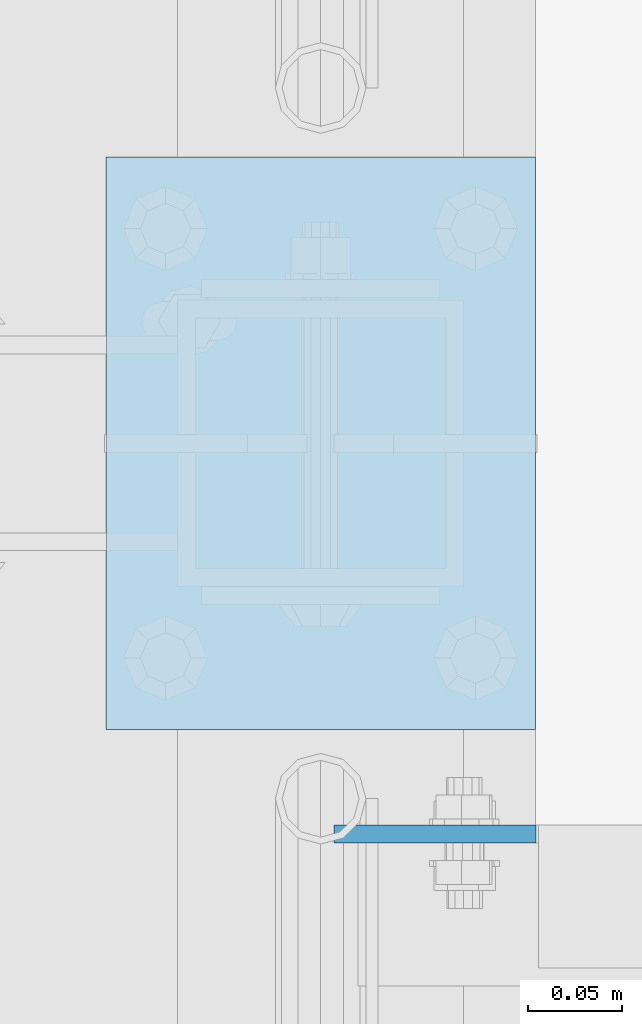
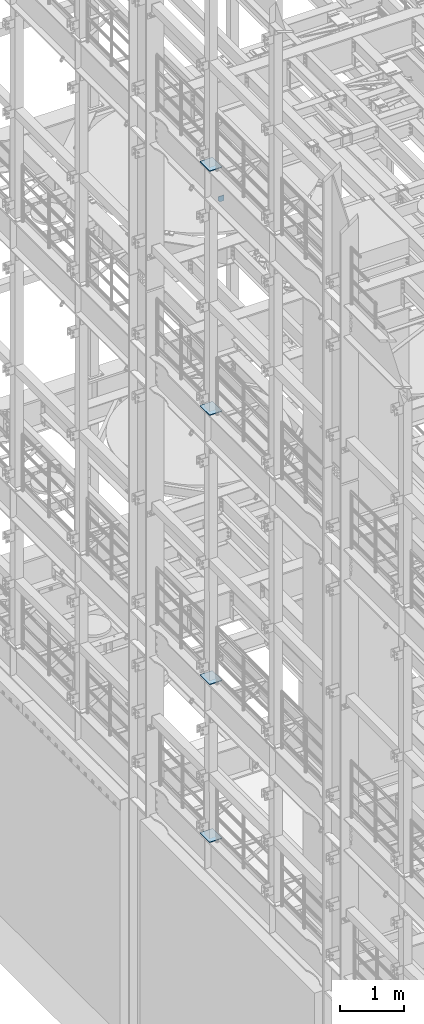
# One storey, part 1620 of 1876: 5 plates, 5 elements without a shape of their own.
"""IFC2X3 building model written with IfcOpenShell, lengths in millimetres."""

import ifcopenshell
import ifcopenshell.guid

model = None  # the IFC model being written
_history = None  # IfcOwnerHistory: only IFC2X3 demands one
_inside = {}  # id of a spatial element -> (the spatial element, [elements in it])
_under = {}  # id of a project, library or spatial element -> (it, [spatial elements below it])
_declared = {}  # id of a project -> (the project, [libraries it declares])
_typed = {}  # id of a type object -> (the type object, [elements of that type])
_made_of = {}  # id of a material, layer set ... -> (it, [elements and type objects made of it])


def new_model(schema):
    """Start an empty IFC model of exactly this schema.

    Asked for "IFC4X3", IfcOpenShell would pick the latest addendum, in which some entities
    have other attributes; the version numbers below select the first issue.
    IFC2X3 requires an IfcOwnerHistory on every rooted entity: one is made here for all.
    """
    global model, _history
    if schema == "IFC4X3":
        model = ifcopenshell.file(schema_version=(4, 3, 0, 0))
    else:
        model = ifcopenshell.file(schema=schema)
    _inside.clear()
    _under.clear()
    _declared.clear()
    _typed.clear()
    _made_of.clear()
    _history = None
    if model.schema == "IFC2X3":
        org = make("IfcOrganization", Name="unknown")
        user = make(
            "IfcPersonAndOrganization",
            ThePerson=make("IfcPerson", FamilyName="unknown"),
            TheOrganization=org,
        )
        app = make(
            "IfcApplication",
            ApplicationDeveloper=org,
            Version="unknown",
            ApplicationFullName="unknown",
            ApplicationIdentifier="unknown",
        )
        _history = make(
            "IfcOwnerHistory",
            OwningUser=user,
            OwningApplication=app,
            ChangeAction="ADDED",
            CreationDate=0,
        )
    return model


def make(cls, **values):
    """One entity of the class cls with the attributes given. An attribute that is None is left unset."""
    return model.create_entity(
        cls, **{name: value for name, value in values.items() if value is not None}
    )


def rooted(cls, **values):
    """An entity with a GlobalId (a new one), such as an element, a storey or a relation."""
    return make(cls, GlobalId=ifcopenshell.guid.new(), OwnerHistory=_history, **values)


def si_unit(unit_type, name, prefix=None):
    """IfcSIUnit, for example si_unit("LENGTHUNIT", "METRE", prefix="MILLI")."""
    return make("IfcSIUnit", UnitType=unit_type, Prefix=prefix, Name=name)


def assignment(units):
    """IfcUnitAssignment: the units of a project."""
    return None if units is None else make("IfcUnitAssignment", Units=units)


def point(xyz):
    """IfcCartesianPoint."""
    return None if xyz is None else make("IfcCartesianPoint", Coordinates=xyz)


def direction(xyz):
    """IfcDirection."""
    return None if xyz is None else make("IfcDirection", DirectionRatios=xyz)


def frame(location, z_axis=None, x_axis=None):
    """IfcAxis2Placement3D, a coordinate frame: its origin and axes. An axis left out is left unset."""
    return make(
        "IfcAxis2Placement3D",
        Location=point(location),
        Axis=direction(z_axis),
        RefDirection=direction(x_axis),
    )


def origin_with_axes():
    """The frame at (0, 0, 0) with the z axis (0, 0, 1) and the x axis (1, 0, 0) written out."""
    return frame((0.0, 0.0, 0.0), z_axis=(0.0, 0.0, 1.0), x_axis=(1.0, 0.0, 0.0))


def place(relative_to, where):
    """IfcLocalPlacement: puts the frame where relative to a parent placement (None: the world)."""
    return make(
        "IfcLocalPlacement", PlacementRelTo=relative_to, RelativePlacement=where
    )


def context(
    kind, dimensions, precision=None, world=None, true_north=None, identifier=None
):
    """IfcGeometricRepresentationContext, for example the 3D "Model" context."""
    return make(
        "IfcGeometricRepresentationContext",
        ContextIdentifier=identifier,
        ContextType=kind,
        CoordinateSpaceDimension=dimensions,
        Precision=precision,
        WorldCoordinateSystem=world,
        TrueNorth=true_north,
    )


def subcontext(parent, identifier, kind, view, scale=None):
    """IfcGeometricRepresentationSubContext, for example "Body" below "Model"."""
    return make(
        "IfcGeometricRepresentationSubContext",
        ContextIdentifier=identifier,
        ContextType=kind,
        ParentContext=parent,
        TargetScale=scale,
        TargetView=view,
    )


def project(units=None, contexts=None):
    """IfcProject with its units and contexts."""
    return rooted(
        "IfcProject",
        Name="project",
        RepresentationContexts=contexts,
        UnitsInContext=assignment(units),
    )


def spatial(cls, under=None, at=None, **own):
    """A site, building, storey or space (cls), placed at a placement, below another one or the project."""
    s = rooted(cls, ObjectPlacement=at, **own)
    if under is not None:
        _under.setdefault(under.id(), (under, []))[1].append(s)
    return s


def faces_of(points, faces, orient=None, outer=None):
    """IfcFace entities. A face is a list of loops; a loop is a list of indices into points, from 0.

    orient and outer hold one flag for each loop. By default every Orientation is true, the
    first loop of a face is its IfcFaceOuterBound and the others are IfcFaceBound.
    """
    made = []
    for i, loops in enumerate(faces):
        bounds = []
        for j, loop in enumerate(loops):
            is_outer = j == 0 if outer is None else outer[i][j]
            bounds.append(
                make(
                    "IfcFaceOuterBound" if is_outer else "IfcFaceBound",
                    Bound=make("IfcPolyLoop", Polygon=[points[k] for k in loop]),
                    Orientation=True if orient is None else orient[i][j],
                )
            )
        made.append(make("IfcFace", Bounds=bounds))
    return made


def faceted_brep(points, faces, orient=None, outer=None, voids=None):
    """IfcFacetedBrep: a solid bounded by flat faces; with voids (closed shells), ...WithVoids."""
    shared = [point(p) for p in points]
    hull = make("IfcClosedShell", CfsFaces=faces_of(shared, faces, orient, outer))
    if voids is None:
        return make("IfcFacetedBrep", Outer=hull)
    return make(
        "IfcFacetedBrepWithVoids",
        Outer=hull,
        Voids=[
            make(cls, CfsFaces=faces_of(shared, fs, o, b)) for cls, fs, o, b in voids
        ],
    )


def shape(context_of_items, identifier, shape_type, items):
    """IfcShapeRepresentation: the items that make up one representation, for example the "Body"."""
    return make(
        "IfcShapeRepresentation",
        ContextOfItems=context_of_items,
        RepresentationIdentifier=identifier,
        RepresentationType=shape_type,
        Items=items,
    )


def material(Name=None, Category=None):
    """IfcMaterial."""
    return make("IfcMaterial", Name=Name, Category=Category)


def made_of(thing, what):
    """Note that an element or type object is made of a material, layer set ...; save() writes the relation."""
    if what is not None:
        _made_of.setdefault(what.id(), (what, []))[1].append(thing)
    return thing


def type_object(cls, material=None, **own):
    """A type object (cls), such as IfcWallType, which elements share."""
    return made_of(rooted(cls, **own), material)


def element(
    cls,
    number,
    at=None,
    inside=None,
    cuts=None,
    type_object=None,
    material=None,
    context=None,
    identifier="Body",
    shape_type=None,
    held_by="IfcProductDefinitionShape",
    body=None,
    shapes=None,
    **own,
):
    """One element of the class cls, such as IfcWall. Its Tag is "e" and its number.

    at: its placement. inside: the storey or other place that contains it. cuts: it is an
    opening in that element (IfcRelVoidsElement). A single representation is given by context,
    identifier, shape_type and body (its items); several are given by shapes. held_by: the class
    of the entity that holds the representations. save() writes the other relations.
    """
    e = rooted(cls, Tag="e%d" % number, ObjectPlacement=at, **own)
    if body is not None:
        shapes = [shape(context, identifier, shape_type, body)]
    if shapes is not None:
        e.Representation = make(held_by, Representations=shapes)
    if inside is not None:
        _inside.setdefault(inside.id(), (inside, []))[1].append(e)
    if cuts is not None:
        rooted(
            "IfcRelVoidsElement", RelatingBuildingElement=cuts, RelatedOpeningElement=e
        )
    if type_object is not None:
        _typed.setdefault(type_object.id(), (type_object, []))[1].append(e)
    return made_of(e, material)


def aggregate(whole, parts):
    """IfcRelAggregates: a whole, such as a stair, and the parts it consists of."""
    return rooted("IfcRelAggregates", RelatingObject=whole, RelatedObjects=parts)


def save(model, path):
    """Write the relations noted so far, then the file.

    IfcRelAggregates (storeys below a building ...), IfcRelContainedInSpatialStructure (elements
    in a storey), IfcRelDefinesByType, IfcRelAssociatesMaterial and IfcRelDeclares: one each for
    every whole, place, type object, material and project.
    """
    for whole, parts in _under.values():
        aggregate(whole, parts)
    for where, things in _inside.values():
        rooted(
            "IfcRelContainedInSpatialStructure",
            RelatedElements=things,
            RelatingStructure=where,
        )
    for kind, things in _typed.values():
        rooted("IfcRelDefinesByType", RelatedObjects=things, RelatingType=kind)
    for what, things in _made_of.values():
        rooted("IfcRelAssociatesMaterial", RelatedObjects=things, RelatingMaterial=what)
    for by, libraries in _declared.values():
        rooted("IfcRelDeclares", RelatingContext=by, RelatedDefinitions=libraries)
    model.write(path)


model = new_model("IFC2X3")

# Units and contexts
model_context = context("Model", 3, precision=1e-05, world=origin_with_axes())
body_context = subcontext(model_context, "Body", "Model", "MODEL_VIEW")
ifc_project = project(units=[si_unit("LENGTHUNIT", "METRE", prefix="MILLI"), si_unit("AREAUNIT", "SQUARE_METRE"), si_unit("VOLUMEUNIT", "CUBIC_METRE"), si_unit("MASSUNIT", "GRAM", prefix="KILO"), si_unit("TIMEUNIT", "SECOND"), si_unit("PLANEANGLEUNIT", "RADIAN"), si_unit("SOLIDANGLEUNIT", "STERADIAN"), si_unit("THERMODYNAMICTEMPERATUREUNIT", "DEGREE_CELSIUS"), si_unit("LUMINOUSINTENSITYUNIT", "LUMEN")], contexts=[model_context])

# Site, building, storey
site_placement = place(None, origin_with_axes())
site = spatial("IfcSite", under=ifc_project, at=site_placement, CompositionType="ELEMENT")
building_placement = place(site_placement, origin_with_axes())
building = spatial("IfcBuilding", under=site, at=building_placement, Name="Undefined", CompositionType="ELEMENT")
storey_placement = place(building_placement, origin_with_axes())
storey = spatial("IfcBuildingStorey", under=building, at=storey_placement, Name="Undefined", CompositionType="ELEMENT", Elevation=0.0)

# Assembly, plate
assembly_1_placement = place(storey_placement, origin_with_axes())
assembly_1 = element("IfcElementAssembly", 1, at=assembly_1_placement, inside=storey, Name="BEAM", AssemblyPlace="NOTDEFINED", PredefinedType="RIGID_FRAME")
ifc_material = material(Name="STEEL/A36")
plate_type_1 = type_object("IfcPlateType", PredefinedType="NOTDEFINED")
plate_1_placement = place(assembly_1_placement, frame((114.570656047482, 5380.0375, 17386.3), z_axis=(-1.0, 0.0, 0.0), x_axis=(0.0, 0.0, 1.0)))
plate_1 = element("IfcPlate", 2, at=plate_1_placement, type_object=plate_type_1, material=ifc_material, Name="PLATE", context=body_context, shape_type="Brep", body=[
    faceted_brep([(0.0, -4.76249999999982, 0.0), (0.0, -4.76249999999982, 75.6769027709961), (0.0, 4.76249999999982, 75.6769027709961), (0.0, 4.76249999999982, 0.0), (31.75, -4.76249999999982, 107.426902770996), (31.75, 4.76249999999982, 107.426902770996), (106.270881652832, -4.76249999999982, 107.426902770996), (106.270881652832, 4.76249999999982, 107.426902770996), (106.270881652832, -4.76249999999982, 0.0), (106.270881652832, 4.76249999999982, 0.0)], [[[0, 1, 2, 3]], [[1, 4, 5, 2]], [[4, 6, 7, 5]], [[6, 8, 9, 7]], [[8, 0, 3, 9]], [[5, 7, 9, 3, 2]], [[8, 6, 4, 1, 0]]]),
])
aggregate(assembly_1, [plate_1])

assembly_2_placement = place(storey_placement, origin_with_axes())
assembly_2 = element("IfcElementAssembly", 3, at=assembly_2_placement, inside=storey, Name="BEAM", AssemblyPlace="NOTDEFINED", PredefinedType="RIGID_FRAME")
plate_type_2 = type_object("IfcPlateType", PredefinedType="NOTDEFINED")
plate_2_placement = place(assembly_2_placement, frame((-114.3, 5435.6, 17989.55), z_axis=(0.0, 1.0, 0.0), x_axis=(1.0, 0.0, 0.0)))
plate_2 = element("IfcPlate", 4, at=plate_2_placement, type_object=plate_type_2, material=ifc_material, Name="PLATE", context=body_context, shape_type="Brep", body=[
    faceted_brep([(0.0, -6.35000000000036, 0.0), (0.0, -6.35000000000036, 304.799987792969), (0.0, 6.35000000000036, 304.799987792969), (0.0, 6.35000000000036, 0.0), (228.600006103516, -6.34999999999854, 304.799987792969), (228.600006103516, 6.34999999999854, 304.799987792969), (228.600006103516, -6.34999999999854, 0.0), (228.600006103516, 6.34999999999854, 0.0)], [[[0, 1, 2, 3]], [[1, 4, 5, 2]], [[4, 6, 7, 5]], [[6, 0, 3, 7]], [[5, 7, 3, 2]], [[6, 4, 1, 0]]]),
])
aggregate(assembly_2, [plate_2])

assembly_3_placement = place(storey_placement, origin_with_axes())
assembly_3 = element("IfcElementAssembly", 5, at=assembly_3_placement, inside=storey, Name="BEAM", AssemblyPlace="NOTDEFINED", PredefinedType="RIGID_FRAME")
plate_3_placement = place(assembly_3_placement, frame((-114.3, 5435.6, 13315.95), z_axis=(0.0, 1.0, 0.0), x_axis=(1.0, 0.0, 0.0)))
plate_3 = element("IfcPlate", 6, at=plate_3_placement, type_object=plate_type_2, material=ifc_material, Name="PLATE", context=body_context, shape_type="Brep", body=[
    faceted_brep([(0.0, -6.35000000000036, 0.0), (0.0, -6.35000000000036, 304.799987792969), (0.0, 6.35000000000036, 304.799987792969), (0.0, 6.35000000000036, 0.0), (228.600006103516, -6.34999999999854, 304.799987792969), (228.600006103516, 6.34999999999854, 304.799987792969), (228.600006103516, -6.34999999999854, 0.0), (228.600006103516, 6.34999999999854, 0.0)], [[[0, 1, 2, 3]], [[1, 4, 5, 2]], [[4, 6, 7, 5]], [[6, 0, 3, 7]], [[5, 7, 3, 2]], [[6, 4, 1, 0]]]),
])
aggregate(assembly_3, [plate_3])

assembly_4_placement = place(storey_placement, origin_with_axes())
assembly_4 = element("IfcElementAssembly", 7, at=assembly_4_placement, inside=storey, Name="BEAM", AssemblyPlace="NOTDEFINED", PredefinedType="RIGID_FRAME")
plate_4_placement = place(assembly_4_placement, frame((-114.3, 5435.6, 8159.75), z_axis=(0.0, 1.0, 0.0), x_axis=(1.0, 0.0, 0.0)))
plate_4 = element("IfcPlate", 8, at=plate_4_placement, type_object=plate_type_2, material=ifc_material, Name="PLATE", context=body_context, shape_type="Brep", body=[
    faceted_brep([(0.0, -6.35000000000036, 0.0), (0.0, -6.35000000000036, 304.799987792969), (0.0, 6.35000000000036, 304.799987792969), (0.0, 6.35000000000036, 0.0), (228.600006103516, -6.34999999999854, 304.799987792969), (228.600006103516, 6.34999999999854, 304.799987792969), (228.600006103516, -6.34999999999854, 0.0), (228.600006103516, 6.34999999999854, 0.0)], [[[0, 1, 2, 3]], [[1, 4, 5, 2]], [[4, 6, 7, 5]], [[6, 0, 3, 7]], [[5, 7, 3, 2]], [[6, 4, 1, 0]]]),
])
aggregate(assembly_4, [plate_4])

assembly_5_placement = place(storey_placement, origin_with_axes())
assembly_5 = element("IfcElementAssembly", 9, at=assembly_5_placement, inside=storey, Name="BEAM", AssemblyPlace="NOTDEFINED", PredefinedType="RIGID_FRAME")
plate_5_placement = place(assembly_5_placement, frame((-114.3, 5435.6, 5137.15), z_axis=(0.0, 1.0, 0.0), x_axis=(1.0, 0.0, 0.0)))
plate_5 = element("IfcPlate", 10, at=plate_5_placement, type_object=plate_type_2, material=ifc_material, Name="PLATE", context=body_context, shape_type="Brep", body=[
    faceted_brep([(0.0, -6.35000000000036, 0.0), (0.0, -6.35000000000036, 304.799987792969), (0.0, 6.35000000000036, 304.799987792969), (0.0, 6.35000000000036, 0.0), (228.600006103516, -6.34999999999854, 304.799987792969), (228.600006103516, 6.34999999999854, 304.799987792969), (228.600006103516, -6.34999999999854, 0.0), (228.600006103516, 6.34999999999854, 0.0)], [[[0, 1, 2, 3]], [[1, 4, 5, 2]], [[4, 6, 7, 5]], [[6, 0, 3, 7]], [[5, 7, 3, 2]], [[6, 4, 1, 0]]]),
])
aggregate(assembly_5, [plate_5])

save(model, "model.ifc")
